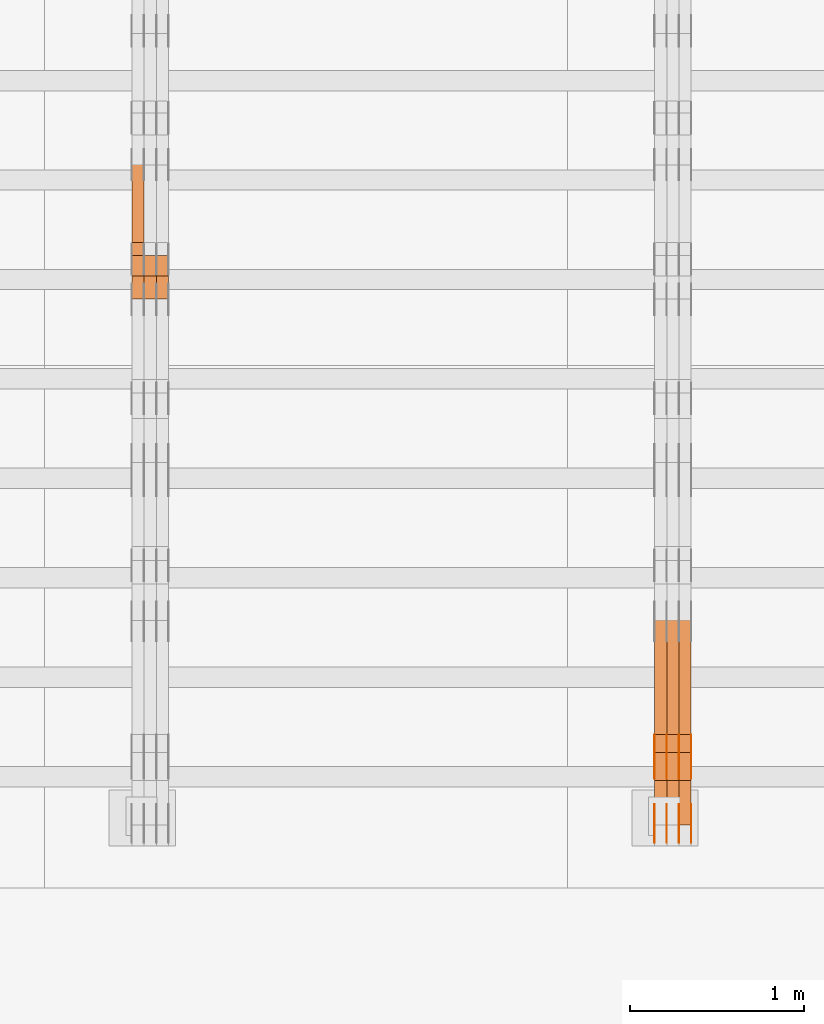
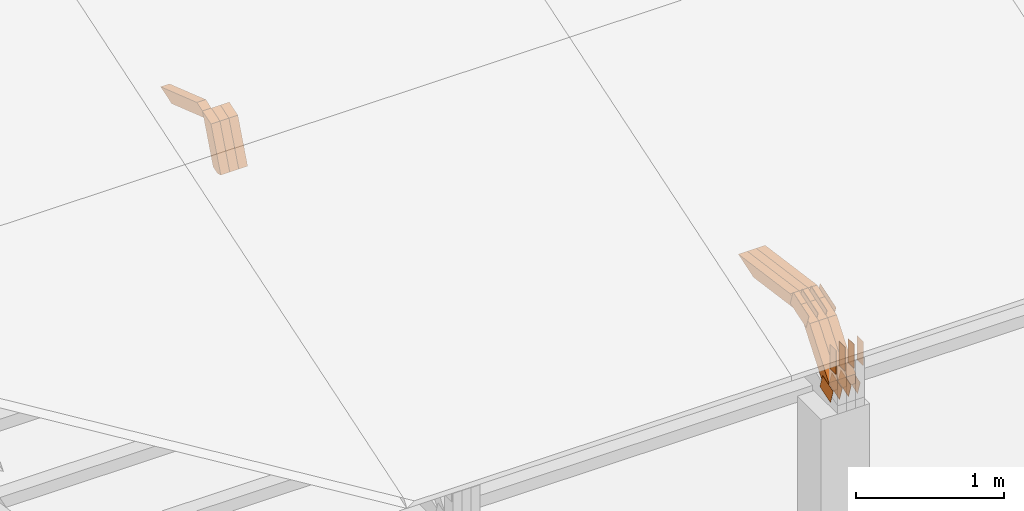
# One storey, part 128 of 385: 28 proxies.
"""IFC2X3 building model written with IfcOpenShell, lengths in millimetres."""

from ifc_helpers import new_model, entity, si_unit, converted_unit, derived_unit, direction, frame, frame_2d, origin, place, context, subcontext, project, spatial, polyline, rectangle, outline, extrude, source, transform, mapped, material, type_object, type_shapes, element, save


model = new_model("IFC2X3")

# Units and contexts
model_context = context("Model", 3, precision=0.01, world=origin(), true_north=direction((6.12303176911189e-17, 1.0)))
body_context = subcontext(model_context, "Body", "Model", "MODEL_VIEW")
ifc_project = project(units=[si_unit("LENGTHUNIT", "METRE", prefix="MILLI"), si_unit("AREAUNIT", "SQUARE_METRE"), si_unit("VOLUMEUNIT", "CUBIC_METRE"), converted_unit("PLANEANGLEUNIT", "DEGREE", entity("IfcRatioMeasure", 0.0174532925199433), si_unit("PLANEANGLEUNIT", "RADIAN"), dimensions=[0, 0, 0, 0, 0, 0, 0]), si_unit("MASSUNIT", "GRAM", prefix="KILO"), derived_unit("MASSDENSITYUNIT", [(si_unit("MASSUNIT", "GRAM", prefix="KILO"), 1), (si_unit("LENGTHUNIT", "METRE"), -3)]), si_unit("TIMEUNIT", "SECOND"), si_unit("FREQUENCYUNIT", "HERTZ"), si_unit("THERMODYNAMICTEMPERATUREUNIT", "DEGREE_CELSIUS"), derived_unit("THERMALTRANSMITTANCEUNIT", [(si_unit("MASSUNIT", "GRAM", prefix="KILO"), 1), (si_unit("THERMODYNAMICTEMPERATUREUNIT", "KELVIN"), -1), (si_unit("TIMEUNIT", "SECOND"), -3)]), derived_unit("VOLUMETRICFLOWRATEUNIT", [(si_unit("LENGTHUNIT", "METRE"), 3), (si_unit("TIMEUNIT", "SECOND"), -1)]), si_unit("ELECTRICCURRENTUNIT", "AMPERE"), si_unit("ELECTRICVOLTAGEUNIT", "VOLT"), si_unit("POWERUNIT", "WATT"), si_unit("FORCEUNIT", "NEWTON", prefix="KILO"), si_unit("ILLUMINANCEUNIT", "LUX"), si_unit("LUMINOUSFLUXUNIT", "LUMEN"), si_unit("LUMINOUSINTENSITYUNIT", "CANDELA"), derived_unit("USERDEFINED", [(si_unit("MASSUNIT", "GRAM", prefix="KILO"), -1), (si_unit("LENGTHUNIT", "METRE"), -2), (si_unit("TIMEUNIT", "SECOND"), 3), (si_unit("LUMINOUSFLUXUNIT", "LUMEN"), 1)]), derived_unit("LINEARVELOCITYUNIT", [(si_unit("LENGTHUNIT", "METRE"), 1), (si_unit("TIMEUNIT", "SECOND"), -1)]), si_unit("PRESSUREUNIT", "PASCAL"), derived_unit("USERDEFINED", [(si_unit("LENGTHUNIT", "METRE"), -2), (si_unit("MASSUNIT", "GRAM", prefix="KILO"), 1), (si_unit("TIMEUNIT", "SECOND"), -2)])], contexts=[model_context])

# Site, building, storey
site_placement = place(None, origin())
site = spatial("IfcSite", under=ifc_project, at=site_placement, CompositionType="ELEMENT")
building_placement = place(site_placement, origin())
building = spatial("IfcBuilding", under=site, at=building_placement, CompositionType="ELEMENT")
storey_placement = place(building_placement, origin())
storey = spatial("IfcBuildingStorey", under=building, at=storey_placement, Name="Default", CompositionType="ELEMENT", Elevation=0.0)

# Proxies
ifc_material_1 = material(Name="IfcSurfaceStyle #374460")
building_element_proxy_type_1 = type_object("IfcBuildingElementProxyType", PredefinedType="NOTDEFINED", material=ifc_material_1)
shared_shape_1 = source(origin(), body_context, "Body", "SweptSolid", [
    extrude(outline(polyline([(-74.999865408764, -60.0000379172698), (74.9998729365771, -60.0000379172698), (74.9998642299588, 60.0000379172698), (-74.9998717577719, 60.0000379172698), (-74.999865408764, -60.0000379172698)])), frame((75.0005044383734, 60.0001679035349, 0.0), z_axis=(0.0, 0.0, 1.0), x_axis=(-1.0, 0.0, 0.0)), (0.0, 0.0, 1.0), 1.3),
])
type_shapes(building_element_proxy_type_1, [shared_shape_1])
proxy_1_placement = place(building_placement, frame((30386.3, 2998.66143710397, 150.423871180894), z_axis=(-1.0, 0.0, 0.0), x_axis=(0.0, 0.951056516295124, 0.309016994375039)))
element("IfcBuildingElementProxy", 1, at=proxy_1_placement, inside=storey, type_object=building_element_proxy_type_1, material=ifc_material_1, context=body_context, shape_type="MappedRepresentation", body=[
    mapped(shared_shape_1, transform((0.0, 0.0, 0.0), scale=1.0)),
])
ifc_material_2 = material(Name="IfcSurfaceStyle #374403")
building_element_proxy_type_2 = type_object("IfcBuildingElementProxyType", PredefinedType="NOTDEFINED", material=ifc_material_2)
shared_shape_2 = source(origin(), body_context, "Body", "SweptSolid", [
    extrude(outline(polyline([(-74.999865408764, -60.0000379172698), (74.9998729365771, -60.0000379172698), (74.9998642299588, 60.0000379172698), (-74.9998717577719, 60.0000379172698), (-74.999865408764, -60.0000379172698)])), frame((75.0005044383734, 60.0001679035349, 0.0), z_axis=(0.0, 0.0, 1.0), x_axis=(-1.0, 0.0, 0.0)), (0.0, 0.0, 1.0), 1.3),
])
type_shapes(building_element_proxy_type_2, [shared_shape_2])
proxy_2_placement = place(building_placement, frame((30315.0, 2998.66143710397, 150.423871180894), z_axis=(-1.0, 0.0, 0.0), x_axis=(0.0, 0.951056516295124, 0.309016994375039)))
element("IfcBuildingElementProxy", 2, at=proxy_2_placement, inside=storey, type_object=building_element_proxy_type_2, material=ifc_material_2, context=body_context, shape_type="MappedRepresentation", body=[
    mapped(shared_shape_2, transform((0.0, 0.0, 0.0), scale=1.0)),
])
ifc_material_3 = material(Name="IfcSurfaceStyle #374346")
building_element_proxy_type_3 = type_object("IfcBuildingElementProxyType", PredefinedType="NOTDEFINED", material=ifc_material_3)
shared_shape_3 = source(origin(), body_context, "Body", "SweptSolid", [
    extrude(outline(polyline([(-74.999865408764, -60.0000379172698), (74.9998729365771, -60.0000379172698), (74.9998642299588, 60.0000379172698), (-74.9998717577719, 60.0000379172698), (-74.999865408764, -60.0000379172698)])), frame((75.0005044383734, 60.0001679035349, 0.0), z_axis=(0.0, 0.0, 1.0), x_axis=(-1.0, 0.0, 0.0)), (0.0, 0.0, 1.0), 1.3),
])
type_shapes(building_element_proxy_type_3, [shared_shape_3])
proxy_3_placement = place(building_placement, frame((30316.3, 2998.66143710397, 150.423871180894), z_axis=(-1.0, 0.0, 0.0), x_axis=(0.0, 0.951056516295124, 0.309016994375039)))
element("IfcBuildingElementProxy", 3, at=proxy_3_placement, inside=storey, type_object=building_element_proxy_type_3, material=ifc_material_3, context=body_context, shape_type="MappedRepresentation", body=[
    mapped(shared_shape_3, transform((0.0, 0.0, 0.0), scale=1.0)),
])
ifc_material_4 = material(Name="IfcSurfaceStyle #374289")
building_element_proxy_type_4 = type_object("IfcBuildingElementProxyType", PredefinedType="NOTDEFINED", material=ifc_material_4)
shared_shape_4 = source(origin(), body_context, "Body", "SweptSolid", [
    extrude(outline(polyline([(-74.999865408764, -60.0000379172698), (74.9998729365771, -60.0000379172698), (74.9998642299588, 60.0000379172698), (-74.9998717577719, 60.0000379172698), (-74.999865408764, -60.0000379172698)])), frame((75.0005044383734, 60.0001679035349, 0.0), z_axis=(0.0, 0.0, 1.0), x_axis=(-1.0, 0.0, 0.0)), (0.0, 0.0, 1.0), 1.29999999999999),
])
type_shapes(building_element_proxy_type_4, [shared_shape_4])
proxy_4_placement = place(building_placement, frame((30245.0, 2998.66143710397, 150.423871180894), z_axis=(-1.0, 0.0, 0.0), x_axis=(0.0, 0.951056516295124, 0.309016994375039)))
element("IfcBuildingElementProxy", 4, at=proxy_4_placement, inside=storey, type_object=building_element_proxy_type_4, material=ifc_material_4, context=body_context, shape_type="MappedRepresentation", body=[
    mapped(shared_shape_4, transform((0.0, 0.0, 0.0), scale=1.0)),
])
ifc_material_5 = material(Name="IfcSurfaceStyle #374232")
building_element_proxy_type_5 = type_object("IfcBuildingElementProxyType", PredefinedType="NOTDEFINED", material=ifc_material_5)
shared_shape_5 = source(origin(), body_context, "Body", "SweptSolid", [
    extrude(outline(polyline([(-74.999865408764, -60.0000379172698), (74.9998729365771, -60.0000379172698), (74.9998642299588, 60.0000379172698), (-74.9998717577719, 60.0000379172698), (-74.999865408764, -60.0000379172698)])), frame((75.0005044383734, 60.0001679035349, 0.0), z_axis=(0.0, 0.0, 1.0), x_axis=(-1.0, 0.0, 0.0)), (0.0, 0.0, 1.0), 1.29999999999999),
])
type_shapes(building_element_proxy_type_5, [shared_shape_5])
proxy_5_placement = place(building_placement, frame((30246.3, 2998.66143710397, 150.423871180894), z_axis=(-1.0, 0.0, 0.0), x_axis=(0.0, 0.951056516295124, 0.309016994375039)))
element("IfcBuildingElementProxy", 5, at=proxy_5_placement, inside=storey, type_object=building_element_proxy_type_5, material=ifc_material_5, context=body_context, shape_type="MappedRepresentation", body=[
    mapped(shared_shape_5, transform((0.0, 0.0, 0.0), scale=1.0)),
])
ifc_material_6 = material(Name="IfcSurfaceStyle #374175")
building_element_proxy_type_6 = type_object("IfcBuildingElementProxyType", PredefinedType="NOTDEFINED", material=ifc_material_6)
shared_shape_6 = source(origin(), body_context, "Body", "SweptSolid", [
    extrude(outline(polyline([(-74.999865408764, -60.0000379172698), (74.9998729365771, -60.0000379172698), (74.9998642299588, 60.0000379172698), (-74.9998717577719, 60.0000379172698), (-74.999865408764, -60.0000379172698)])), frame((75.0005044383734, 60.0001679035349, 0.0), z_axis=(0.0, 0.0, 1.0), x_axis=(-1.0, 0.0, 0.0)), (0.0, 0.0, 1.0), 1.29999999999999),
])
type_shapes(building_element_proxy_type_6, [shared_shape_6])
proxy_6_placement = place(building_placement, frame((30175.0, 2998.66143710397, 150.423871180894), z_axis=(-1.0, 0.0, 0.0), x_axis=(0.0, 0.951056516295124, 0.309016994375039)))
element("IfcBuildingElementProxy", 6, at=proxy_6_placement, inside=storey, type_object=building_element_proxy_type_6, material=ifc_material_6, context=body_context, shape_type="MappedRepresentation", body=[
    mapped(shared_shape_6, transform((0.0, 0.0, 0.0), scale=1.0)),
])
ifc_material_7 = material(Name="IfcSurfaceStyle #365910")
building_element_proxy_type_7 = type_object("IfcBuildingElementProxyType", PredefinedType="NOTDEFINED", material=ifc_material_7)
shared_shape_7 = source(origin(), body_context, "Body", "SweptSolid", [
    extrude(outline(polyline([(-112.500266735783, -59.9999130784581), (112.500275442392, -59.9999130784581), (112.500262020557, 59.9999130784582), (-112.500270727166, 59.9999130784581), (-112.500266735783, -59.9999130784581)])), frame((112.500275442392, 60.0001020984692, 0.0), z_axis=(0.0, 0.0, 1.0), x_axis=(-1.0, 0.0, 0.0)), (0.0, 0.0, 1.0), 1.3),
])
type_shapes(building_element_proxy_type_7, [shared_shape_7])
proxy_7_placement = place(building_placement, frame((30386.3, 3327.32420598508, 571.284602786019), z_axis=(-1.0, 0.0, 0.0), x_axis=(0.0, 0.951056516295154, 0.309016994374948)))
element("IfcBuildingElementProxy", 7, at=proxy_7_placement, inside=storey, type_object=building_element_proxy_type_7, material=ifc_material_7, context=body_context, shape_type="MappedRepresentation", body=[
    mapped(shared_shape_7, transform((0.0, 0.0, 0.0), scale=1.0)),
])
ifc_material_8 = material(Name="IfcSurfaceStyle #365853")
building_element_proxy_type_8 = type_object("IfcBuildingElementProxyType", PredefinedType="NOTDEFINED", material=ifc_material_8)
shared_shape_8 = source(origin(), body_context, "Body", "SweptSolid", [
    extrude(outline(polyline([(-112.500266735783, -59.9999130784581), (112.500275442392, -59.9999130784581), (112.500262020557, 59.9999130784582), (-112.500270727166, 59.9999130784581), (-112.500266735783, -59.9999130784581)])), frame((112.500275442392, 60.0001020984692, 0.0), z_axis=(0.0, 0.0, 1.0), x_axis=(-1.0, 0.0, 0.0)), (0.0, 0.0, 1.0), 1.3),
])
type_shapes(building_element_proxy_type_8, [shared_shape_8])
proxy_8_placement = place(building_placement, frame((30315.0, 3327.32420598508, 571.284602786019), z_axis=(-1.0, 0.0, 0.0), x_axis=(0.0, 0.951056516295154, 0.309016994374948)))
element("IfcBuildingElementProxy", 8, at=proxy_8_placement, inside=storey, type_object=building_element_proxy_type_8, material=ifc_material_8, context=body_context, shape_type="MappedRepresentation", body=[
    mapped(shared_shape_8, transform((0.0, 0.0, 0.0), scale=1.0)),
])
ifc_material_9 = material(Name="IfcSurfaceStyle #365796")
building_element_proxy_type_9 = type_object("IfcBuildingElementProxyType", PredefinedType="NOTDEFINED", material=ifc_material_9)
shared_shape_9 = source(origin(), body_context, "Body", "SweptSolid", [
    extrude(outline(polyline([(-112.500266735783, -59.9999130784581), (112.500275442392, -59.9999130784581), (112.500262020557, 59.9999130784582), (-112.500270727166, 59.9999130784581), (-112.500266735783, -59.9999130784581)])), frame((112.500275442392, 60.0001020984692, 0.0), z_axis=(0.0, 0.0, 1.0), x_axis=(-1.0, 0.0, 0.0)), (0.0, 0.0, 1.0), 1.3),
])
type_shapes(building_element_proxy_type_9, [shared_shape_9])
proxy_9_placement = place(building_placement, frame((30316.3, 3327.32420598508, 571.284602786019), z_axis=(-1.0, 0.0, 0.0), x_axis=(0.0, 0.951056516295154, 0.309016994374948)))
element("IfcBuildingElementProxy", 9, at=proxy_9_placement, inside=storey, type_object=building_element_proxy_type_9, material=ifc_material_9, context=body_context, shape_type="MappedRepresentation", body=[
    mapped(shared_shape_9, transform((0.0, 0.0, 0.0), scale=1.0)),
])
ifc_material_10 = material(Name="IfcSurfaceStyle #365739")
building_element_proxy_type_10 = type_object("IfcBuildingElementProxyType", PredefinedType="NOTDEFINED", material=ifc_material_10)
shared_shape_10 = source(origin(), body_context, "Body", "SweptSolid", [
    extrude(outline(polyline([(-112.500266735783, -59.9999130784581), (112.500275442392, -59.9999130784581), (112.500262020557, 59.9999130784582), (-112.500270727166, 59.9999130784581), (-112.500266735783, -59.9999130784581)])), frame((112.500275442392, 60.0001020984692, 0.0), z_axis=(0.0, 0.0, 1.0), x_axis=(-1.0, 0.0, 0.0)), (0.0, 0.0, 1.0), 1.29999999999998),
])
type_shapes(building_element_proxy_type_10, [shared_shape_10])
proxy_10_placement = place(building_placement, frame((30245.0, 3327.32420598508, 571.284602786019), z_axis=(-1.0, 0.0, 0.0), x_axis=(0.0, 0.951056516295154, 0.309016994374948)))
element("IfcBuildingElementProxy", 10, at=proxy_10_placement, inside=storey, type_object=building_element_proxy_type_10, material=ifc_material_10, context=body_context, shape_type="MappedRepresentation", body=[
    mapped(shared_shape_10, transform((0.0, 0.0, 0.0), scale=1.0)),
])
ifc_material_11 = material(Name="IfcSurfaceStyle #365682")
building_element_proxy_type_11 = type_object("IfcBuildingElementProxyType", PredefinedType="NOTDEFINED", material=ifc_material_11)
shared_shape_11 = source(origin(), body_context, "Body", "SweptSolid", [
    extrude(outline(polyline([(-112.500266735783, -59.9999130784581), (112.500275442392, -59.9999130784581), (112.500262020557, 59.9999130784582), (-112.500270727166, 59.9999130784581), (-112.500266735783, -59.9999130784581)])), frame((112.500275442392, 60.0001020984692, 0.0), z_axis=(0.0, 0.0, 1.0), x_axis=(-1.0, 0.0, 0.0)), (0.0, 0.0, 1.0), 1.29999999999998),
])
type_shapes(building_element_proxy_type_11, [shared_shape_11])
proxy_11_placement = place(building_placement, frame((30246.3, 3327.32420598508, 571.284602786019), z_axis=(-1.0, 0.0, 0.0), x_axis=(0.0, 0.951056516295154, 0.309016994374948)))
element("IfcBuildingElementProxy", 11, at=proxy_11_placement, inside=storey, type_object=building_element_proxy_type_11, material=ifc_material_11, context=body_context, shape_type="MappedRepresentation", body=[
    mapped(shared_shape_11, transform((0.0, 0.0, 0.0), scale=1.0)),
])
ifc_material_12 = material(Name="IfcSurfaceStyle #365625")
building_element_proxy_type_12 = type_object("IfcBuildingElementProxyType", PredefinedType="NOTDEFINED", material=ifc_material_12)
shared_shape_12 = source(origin(), body_context, "Body", "SweptSolid", [
    extrude(outline(polyline([(-112.500266735783, -59.9999130784581), (112.500275442392, -59.9999130784581), (112.500262020557, 59.9999130784582), (-112.500270727166, 59.9999130784581), (-112.500266735783, -59.9999130784581)])), frame((112.500275442392, 60.0001020984692, 0.0), z_axis=(0.0, 0.0, 1.0), x_axis=(-1.0, 0.0, 0.0)), (0.0, 0.0, 1.0), 1.29999999999999),
])
type_shapes(building_element_proxy_type_12, [shared_shape_12])
proxy_12_placement = place(building_placement, frame((30175.0, 3327.32420598508, 571.284602786019), z_axis=(-1.0, 0.0, 0.0), x_axis=(0.0, 0.951056516295154, 0.309016994374948)))
element("IfcBuildingElementProxy", 12, at=proxy_12_placement, inside=storey, type_object=building_element_proxy_type_12, material=ifc_material_12, context=body_context, shape_type="MappedRepresentation", body=[
    mapped(shared_shape_12, transform((0.0, 0.0, 0.0), scale=1.0)),
])
ifc_material_13 = material(Name="IfcSurfaceStyle #364884")
building_element_proxy_type_13 = type_object("IfcBuildingElementProxyType", PredefinedType="NOTDEFINED", material=ifc_material_13)
shared_shape_13 = source(origin(), body_context, "Body", "SweptSolid", [
    extrude(rectangle(XDim=199.999969482422, YDim=84.0, at=frame_2d((1.4210854715202e-14, 0.0), x_axis=(1.0, 0.0))), frame((100.000010815955, 42.0, 0.0), z_axis=(0.0, 0.0, 1.0), x_axis=(-1.0, 0.0, 0.0)), (0.0, 0.0, 1.0), 1.3),
])
type_shapes(building_element_proxy_type_13, [shared_shape_13])
proxy_13_placement = place(building_placement, frame((30386.3, 3042.0, 514.460048047401), z_axis=(-1.0, 0.0, 0.0), x_axis=(0.0, 0.0, -1.0)))
element("IfcBuildingElementProxy", 13, at=proxy_13_placement, inside=storey, type_object=building_element_proxy_type_13, material=ifc_material_13, context=body_context, shape_type="MappedRepresentation", body=[
    mapped(shared_shape_13, transform((0.0, 0.0, 0.0), scale=1.0)),
])
ifc_material_14 = material(Name="IfcSurfaceStyle #364827")
building_element_proxy_type_14 = type_object("IfcBuildingElementProxyType", PredefinedType="NOTDEFINED", material=ifc_material_14)
shared_shape_14 = source(origin(), body_context, "Body", "SweptSolid", [
    extrude(rectangle(XDim=199.999969482422, YDim=84.0, at=frame_2d((1.4210854715202e-14, 0.0), x_axis=(1.0, 0.0))), frame((100.000010815955, 42.0, 0.0), z_axis=(0.0, 0.0, 1.0), x_axis=(-1.0, 0.0, 0.0)), (0.0, 0.0, 1.0), 1.3),
])
type_shapes(building_element_proxy_type_14, [shared_shape_14])
proxy_14_placement = place(building_placement, frame((30315.0, 3042.0, 514.460048047401), z_axis=(-1.0, 0.0, 0.0), x_axis=(0.0, 0.0, -1.0)))
element("IfcBuildingElementProxy", 14, at=proxy_14_placement, inside=storey, type_object=building_element_proxy_type_14, material=ifc_material_14, context=body_context, shape_type="MappedRepresentation", body=[
    mapped(shared_shape_14, transform((0.0, 0.0, 0.0), scale=1.0)),
])
ifc_material_15 = material(Name="IfcSurfaceStyle #364770")
building_element_proxy_type_15 = type_object("IfcBuildingElementProxyType", PredefinedType="NOTDEFINED", material=ifc_material_15)
shared_shape_15 = source(origin(), body_context, "Body", "SweptSolid", [
    extrude(rectangle(XDim=199.999969482422, YDim=84.0, at=frame_2d((1.4210854715202e-14, 0.0), x_axis=(1.0, 0.0))), frame((100.000010815955, 42.0, 0.0), z_axis=(0.0, 0.0, 1.0), x_axis=(-1.0, 0.0, 0.0)), (0.0, 0.0, 1.0), 1.3),
])
type_shapes(building_element_proxy_type_15, [shared_shape_15])
proxy_15_placement = place(building_placement, frame((30316.3, 3042.0, 514.460048047401), z_axis=(-1.0, 0.0, 0.0), x_axis=(0.0, 0.0, -1.0)))
element("IfcBuildingElementProxy", 15, at=proxy_15_placement, inside=storey, type_object=building_element_proxy_type_15, material=ifc_material_15, context=body_context, shape_type="MappedRepresentation", body=[
    mapped(shared_shape_15, transform((0.0, 0.0, 0.0), scale=1.0)),
])
ifc_material_16 = material(Name="IfcSurfaceStyle #364713")
building_element_proxy_type_16 = type_object("IfcBuildingElementProxyType", PredefinedType="NOTDEFINED", material=ifc_material_16)
shared_shape_16 = source(origin(), body_context, "Body", "SweptSolid", [
    extrude(rectangle(XDim=199.999969482422, YDim=84.0, at=frame_2d((1.4210854715202e-14, 0.0), x_axis=(1.0, 0.0))), frame((100.000010815955, 42.0, 0.0), z_axis=(0.0, 0.0, 1.0), x_axis=(-1.0, 0.0, 0.0)), (0.0, 0.0, 1.0), 1.29999999999998),
])
type_shapes(building_element_proxy_type_16, [shared_shape_16])
proxy_16_placement = place(building_placement, frame((30245.0, 3042.0, 514.460048047401), z_axis=(-1.0, 0.0, 0.0), x_axis=(0.0, 0.0, -1.0)))
element("IfcBuildingElementProxy", 16, at=proxy_16_placement, inside=storey, type_object=building_element_proxy_type_16, material=ifc_material_16, context=body_context, shape_type="MappedRepresentation", body=[
    mapped(shared_shape_16, transform((0.0, 0.0, 0.0), scale=1.0)),
])
ifc_material_17 = material(Name="IfcSurfaceStyle #364656")
building_element_proxy_type_17 = type_object("IfcBuildingElementProxyType", PredefinedType="NOTDEFINED", material=ifc_material_17)
shared_shape_17 = source(origin(), body_context, "Body", "SweptSolid", [
    extrude(rectangle(XDim=199.999969482422, YDim=84.0, at=frame_2d((1.4210854715202e-14, 0.0), x_axis=(1.0, 0.0))), frame((100.000010815955, 42.0, 0.0), z_axis=(0.0, 0.0, 1.0), x_axis=(-1.0, 0.0, 0.0)), (0.0, 0.0, 1.0), 1.29999999999998),
])
type_shapes(building_element_proxy_type_17, [shared_shape_17])
proxy_17_placement = place(building_placement, frame((30246.3, 3042.0, 514.460048047401), z_axis=(-1.0, 0.0, 0.0), x_axis=(0.0, 0.0, -1.0)))
element("IfcBuildingElementProxy", 17, at=proxy_17_placement, inside=storey, type_object=building_element_proxy_type_17, material=ifc_material_17, context=body_context, shape_type="MappedRepresentation", body=[
    mapped(shared_shape_17, transform((0.0, 0.0, 0.0), scale=1.0)),
])
ifc_material_18 = material(Name="IfcSurfaceStyle #364599")
building_element_proxy_type_18 = type_object("IfcBuildingElementProxyType", PredefinedType="NOTDEFINED", material=ifc_material_18)
shared_shape_18 = source(origin(), body_context, "Body", "SweptSolid", [
    extrude(rectangle(XDim=199.999969482422, YDim=84.0, at=frame_2d((1.4210854715202e-14, 0.0), x_axis=(1.0, 0.0))), frame((100.000010815955, 42.0, 0.0), z_axis=(0.0, 0.0, 1.0), x_axis=(-1.0, 0.0, 0.0)), (0.0, 0.0, 1.0), 1.29999999999999),
])
type_shapes(building_element_proxy_type_18, [shared_shape_18])
proxy_18_placement = place(building_placement, frame((30175.0, 3042.0, 514.460048047401), z_axis=(-1.0, 0.0, 0.0), x_axis=(0.0, 0.0, -1.0)))
element("IfcBuildingElementProxy", 18, at=proxy_18_placement, inside=storey, type_object=building_element_proxy_type_18, material=ifc_material_18, context=body_context, shape_type="MappedRepresentation", body=[
    mapped(shared_shape_18, transform((0.0, 0.0, 0.0), scale=1.0)),
])
ifc_material_19 = material(Name="IfcSurfaceStyle #353616")
building_element_proxy_type_19 = type_object("IfcBuildingElementProxyType", Name="T1-W3 353614", PredefinedType="NOTDEFINED", material=ifc_material_19)
shared_shape_19 = source(origin(), body_context, "Body", "SweptSolid", [
    extrude(outline(polyline([(-314.232579911788, -47.5000200125938), (325.164873061766, -47.5000200125938), (297.999869081008, 6.48085173424295e-05), (200.434027234171, 47.4999876083351), (-509.366189465157, 47.4999876083352), (-314.232579911788, -47.5000200125938)])), frame((325.164873061766, 47.5001564752191, 0.0), z_axis=(0.0, 0.0, 1.0), x_axis=(-1.0, 0.0, 0.0)), (0.0, 0.0, 1.0), 70.0),
])
type_shapes(building_element_proxy_type_19, [shared_shape_19])
proxy_19_placement = place(building_placement, frame((30385.0, 3457.43747924875, 620.49890325051), z_axis=(-1.0, 0.0, 0.0), x_axis=(0.0, 0.990367219823621, -0.138465771578512)))
element("IfcBuildingElementProxy", 19, at=proxy_19_placement, inside=storey, type_object=building_element_proxy_type_19, material=ifc_material_19, Name="T1-W3", context=body_context, shape_type="MappedRepresentation", body=[
    mapped(shared_shape_19, transform((0.0, 0.0, 0.0), scale=1.0)),
])
ifc_material_20 = material(Name="IfcSurfaceStyle #353550")
building_element_proxy_type_20 = type_object("IfcBuildingElementProxyType", Name="T1-W3 353548", PredefinedType="NOTDEFINED", material=ifc_material_20)
shared_shape_20 = source(origin(), body_context, "Body", "SweptSolid", [
    extrude(outline(polyline([(-314.232579911788, -47.5000200125938), (325.164873061766, -47.5000200125938), (297.999869081008, 6.48085173424295e-05), (200.434027234171, 47.4999876083351), (-509.366189465157, 47.4999876083352), (-314.232579911788, -47.5000200125938)])), frame((325.164873061766, 47.5001564752191, 0.0), z_axis=(0.0, 0.0, 1.0), x_axis=(-1.0, 0.0, 0.0)), (0.0, 0.0, 1.0), 70.0),
])
type_shapes(building_element_proxy_type_20, [shared_shape_20])
proxy_20_placement = place(building_placement, frame((30315.0, 3457.43747924875, 620.49890325051), z_axis=(-1.0, 0.0, 0.0), x_axis=(0.0, 0.990367219823621, -0.138465771578512)))
element("IfcBuildingElementProxy", 20, at=proxy_20_placement, inside=storey, type_object=building_element_proxy_type_20, material=ifc_material_20, Name="T1-W3", context=body_context, shape_type="MappedRepresentation", body=[
    mapped(shared_shape_20, transform((0.0, 0.0, 0.0), scale=1.0)),
])
ifc_material_21 = material(Name="IfcSurfaceStyle #353484")
building_element_proxy_type_21 = type_object("IfcBuildingElementProxyType", Name="T1-W3 353482", PredefinedType="NOTDEFINED", material=ifc_material_21)
shared_shape_21 = source(origin(), body_context, "Body", "SweptSolid", [
    extrude(outline(polyline([(-314.232579911788, -47.5000200125938), (325.164873061766, -47.5000200125938), (297.999869081008, 6.48085173424295e-05), (200.434027234171, 47.4999876083351), (-509.366189465157, 47.4999876083352), (-314.232579911788, -47.5000200125938)])), frame((325.164873061766, 47.5001564752191, 0.0), z_axis=(0.0, 0.0, 1.0), x_axis=(-1.0, 0.0, 0.0)), (0.0, 0.0, 1.0), 70.0),
])
type_shapes(building_element_proxy_type_21, [shared_shape_21])
proxy_21_placement = place(building_placement, frame((30245.0, 3457.43747924875, 620.49890325051), z_axis=(-1.0, 0.0, 0.0), x_axis=(0.0, 0.990367219823621, -0.138465771578512)))
element("IfcBuildingElementProxy", 21, at=proxy_21_placement, inside=storey, type_object=building_element_proxy_type_21, material=ifc_material_21, Name="T1-W3", context=body_context, shape_type="MappedRepresentation", body=[
    mapped(shared_shape_21, transform((0.0, 0.0, 0.0), scale=1.0)),
])
ifc_material_22 = material(Name="IfcSurfaceStyle #353220")
building_element_proxy_type_22 = type_object("IfcBuildingElementProxyType", Name="T1-W14 353218", PredefinedType="NOTDEFINED", material=ifc_material_22)
shared_shape_22 = source(origin(), body_context, "Body", "SweptSolid", [
    extrude(outline(polyline([(-374.484689776928, -47.499919737532), (177.199556189275, -47.499919737532), (246.893257937645, -5.36774925340877e-05), (185.487930694801, 47.4999465762783), (-235.096055044793, 47.4999465762784), (-374.484689776928, -47.499919737532)])), frame((246.893257937645, 47.5000959779252, 0.0), z_axis=(0.0, 0.0, 1.0), x_axis=(-1.0, 0.0, 0.0)), (0.0, 0.0, 1.0), 70.0),
])
type_shapes(building_element_proxy_type_22, [shared_shape_22])
proxy_22_placement = place(building_placement, frame((30385.0, 3022.42877773024, 136.329406512195), z_axis=(-1.0, 0.0, 0.0), x_axis=(0.0, 0.611854146609475, 0.790970608352037)))
element("IfcBuildingElementProxy", 22, at=proxy_22_placement, inside=storey, type_object=building_element_proxy_type_22, material=ifc_material_22, Name="T1-W14", context=body_context, shape_type="MappedRepresentation", body=[
    mapped(shared_shape_22, transform((0.0, 0.0, 0.0), scale=1.0)),
])
ifc_material_23 = material(Name="IfcSurfaceStyle #353154")
building_element_proxy_type_23 = type_object("IfcBuildingElementProxyType", Name="T1-W14 353152", PredefinedType="NOTDEFINED", material=ifc_material_23)
shared_shape_23 = source(origin(), body_context, "Body", "SweptSolid", [
    extrude(outline(polyline([(-374.484689776928, -47.499919737532), (177.199556189275, -47.499919737532), (246.893257937645, -5.36774925340877e-05), (185.487930694801, 47.4999465762783), (-235.096055044793, 47.4999465762784), (-374.484689776928, -47.499919737532)])), frame((246.893257937645, 47.5000959779252, 0.0), z_axis=(0.0, 0.0, 1.0), x_axis=(-1.0, 0.0, 0.0)), (0.0, 0.0, 1.0), 70.0),
])
type_shapes(building_element_proxy_type_23, [shared_shape_23])
proxy_23_placement = place(building_placement, frame((30315.0, 3022.42877773024, 136.329406512195), z_axis=(-1.0, 0.0, 0.0), x_axis=(0.0, 0.611854146609475, 0.790970608352037)))
element("IfcBuildingElementProxy", 23, at=proxy_23_placement, inside=storey, type_object=building_element_proxy_type_23, material=ifc_material_23, Name="T1-W14", context=body_context, shape_type="MappedRepresentation", body=[
    mapped(shared_shape_23, transform((0.0, 0.0, 0.0), scale=1.0)),
])
ifc_material_24 = material(Name="IfcSurfaceStyle #353088")
building_element_proxy_type_24 = type_object("IfcBuildingElementProxyType", Name="T1-W14 353086", PredefinedType="NOTDEFINED", material=ifc_material_24)
shared_shape_24 = source(origin(), body_context, "Body", "SweptSolid", [
    extrude(outline(polyline([(-374.484689776928, -47.499919737532), (177.199556189275, -47.499919737532), (246.893257937645, -5.36774925340877e-05), (185.487930694801, 47.4999465762783), (-235.096055044793, 47.4999465762784), (-374.484689776928, -47.499919737532)])), frame((246.893257937645, 47.5000959779252, 0.0), z_axis=(0.0, 0.0, 1.0), x_axis=(-1.0, 0.0, 0.0)), (0.0, 0.0, 1.0), 70.0),
])
type_shapes(building_element_proxy_type_24, [shared_shape_24])
proxy_24_placement = place(building_placement, frame((30245.0, 3022.42877773024, 136.329406512195), z_axis=(-1.0, 0.0, 0.0), x_axis=(0.0, 0.611854146609475, 0.790970608352037)))
element("IfcBuildingElementProxy", 24, at=proxy_24_placement, inside=storey, type_object=building_element_proxy_type_24, material=ifc_material_24, Name="T1-W14", context=body_context, shape_type="MappedRepresentation", body=[
    mapped(shared_shape_24, transform((0.0, 0.0, 0.0), scale=1.0)),
])
ifc_material_25 = material(Name="IfcSurfaceStyle #321428")
building_element_proxy_type_25 = type_object("IfcBuildingElementProxyType", Name="T1-W19 321426", PredefinedType="NOTDEFINED", material=ifc_material_25)
shared_shape_25 = source(origin(), body_context, "Body", "SweptSolid", [
    extrude(outline(polyline([(-234.986199656822, -47.5000587840676), (221.224626701627, -47.5000587840676), (219.29748584664, -9.04449542012076e-05), (156.014457007826, 47.5001040065446), (-361.550369899272, 47.5001040065447), (-234.986199656822, -47.5000587840676)])), frame((221.224626701627, 47.5001108598228, 0.0), z_axis=(0.0, 0.0, 1.0), x_axis=(-1.0, 0.0, 0.0)), (0.0, 0.0, 1.0), 70.0),
])
type_shapes(building_element_proxy_type_25, [shared_shape_25])
proxy_25_placement = place(building_placement, frame((27245.0, 6342.4042570111, 1541.63383639481), z_axis=(-1.0, 0.0, 0.0), x_axis=(0.0, 0.9461301511345, -0.323786561046329)))
element("IfcBuildingElementProxy", 25, at=proxy_25_placement, inside=storey, type_object=building_element_proxy_type_25, material=ifc_material_25, Name="T1-W19", context=body_context, shape_type="MappedRepresentation", body=[
    mapped(shared_shape_25, transform((0.0, 0.0, 0.0), scale=1.0)),
])
ifc_material_26 = material(Name="IfcSurfaceStyle #321164")
building_element_proxy_type_26 = type_object("IfcBuildingElementProxyType", Name="T1-W46 321162", PredefinedType="NOTDEFINED", material=ifc_material_26)
shared_shape_26 = source(origin(), body_context, "Body", "SweptSolid", [
    extrude(outline(polyline([(-272.224583017384, -47.5002947748381), (128.798007350946, -47.5002947748382), (167.560249082673, 0.000339032424879266), (170.567132940603, 47.500741369691), (-194.700806356838, 47.4995091475604), (-272.224583017384, -47.5002947748381)])), frame((170.567293182179, 47.5001659655231, 0.0), z_axis=(0.0, 0.0, 1.0), x_axis=(-1.0, 3.37347464168628e-06, 0.0)), (0.0, 0.0, 1.0), 70.0),
])
type_shapes(building_element_proxy_type_26, [shared_shape_26])
proxy_26_placement = place(building_placement, frame((27385.0, 6080.046875, 1117.66674804688), z_axis=(-1.0, 0.0, 0.0), x_axis=(0.0, 0.361885618189232, 0.93222250527854)))
element("IfcBuildingElementProxy", 26, at=proxy_26_placement, inside=storey, type_object=building_element_proxy_type_26, material=ifc_material_26, Name="T1-W46", context=body_context, shape_type="MappedRepresentation", body=[
    mapped(shared_shape_26, transform((0.0, 0.0, 0.0), scale=1.0)),
])
ifc_material_27 = material(Name="IfcSurfaceStyle #321098")
building_element_proxy_type_27 = type_object("IfcBuildingElementProxyType", Name="T1-W46 321096", PredefinedType="NOTDEFINED", material=ifc_material_27)
shared_shape_27 = source(origin(), body_context, "Body", "SweptSolid", [
    extrude(outline(polyline([(-272.224583017384, -47.5002947748381), (128.798007350946, -47.5002947748382), (167.560249082673, 0.000339032424879266), (170.567132940603, 47.500741369691), (-194.700806356838, 47.4995091475604), (-272.224583017384, -47.5002947748381)])), frame((170.567293182179, 47.5001659655231, 0.0), z_axis=(0.0, 0.0, 1.0), x_axis=(-1.0, 3.37347464168628e-06, 0.0)), (0.0, 0.0, 1.0), 70.0),
])
type_shapes(building_element_proxy_type_27, [shared_shape_27])
proxy_27_placement = place(building_placement, frame((27315.0, 6080.046875, 1117.66674804688), z_axis=(-1.0, 0.0, 0.0), x_axis=(0.0, 0.361885618189232, 0.93222250527854)))
element("IfcBuildingElementProxy", 27, at=proxy_27_placement, inside=storey, type_object=building_element_proxy_type_27, material=ifc_material_27, Name="T1-W46", context=body_context, shape_type="MappedRepresentation", body=[
    mapped(shared_shape_27, transform((0.0, 0.0, 0.0), scale=1.0)),
])
ifc_material_28 = material(Name="IfcSurfaceStyle #321032")
building_element_proxy_type_28 = type_object("IfcBuildingElementProxyType", Name="T1-W46 321030", PredefinedType="NOTDEFINED", material=ifc_material_28)
shared_shape_28 = source(origin(), body_context, "Body", "SweptSolid", [
    extrude(outline(polyline([(-272.224583017384, -47.5002947748381), (128.798007350946, -47.5002947748382), (167.560249082673, 0.000339032424879266), (170.567132940603, 47.500741369691), (-194.700806356838, 47.4995091475604), (-272.224583017384, -47.5002947748381)])), frame((170.567293182179, 47.5001659655231, 0.0), z_axis=(0.0, 0.0, 1.0), x_axis=(-1.0, 3.37347464168628e-06, 0.0)), (0.0, 0.0, 1.0), 70.0),
])
type_shapes(building_element_proxy_type_28, [shared_shape_28])
proxy_28_placement = place(building_placement, frame((27245.0, 6080.046875, 1117.66674804688), z_axis=(-1.0, 0.0, 0.0), x_axis=(0.0, 0.361885618189232, 0.93222250527854)))
element("IfcBuildingElementProxy", 28, at=proxy_28_placement, inside=storey, type_object=building_element_proxy_type_28, material=ifc_material_28, Name="T1-W46", context=body_context, shape_type="MappedRepresentation", body=[
    mapped(shared_shape_28, transform((0.0, 0.0, 0.0), scale=1.0)),
])

save(model, "model.ifc")
